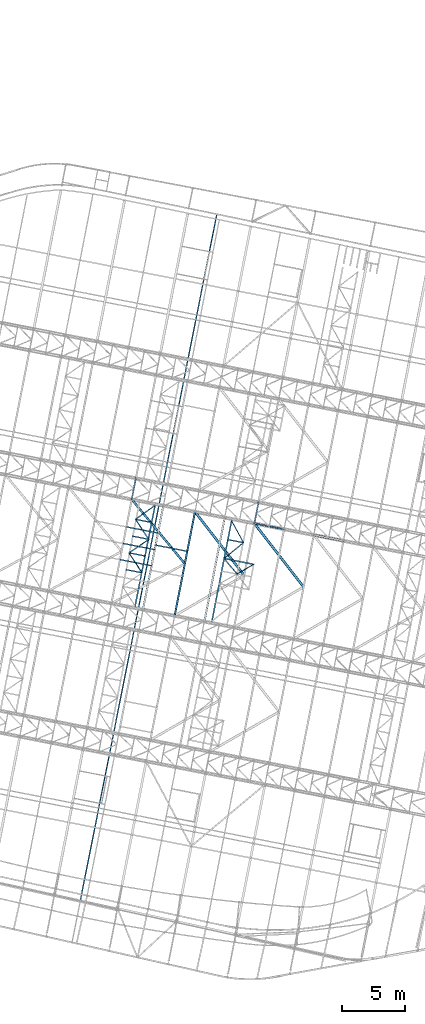
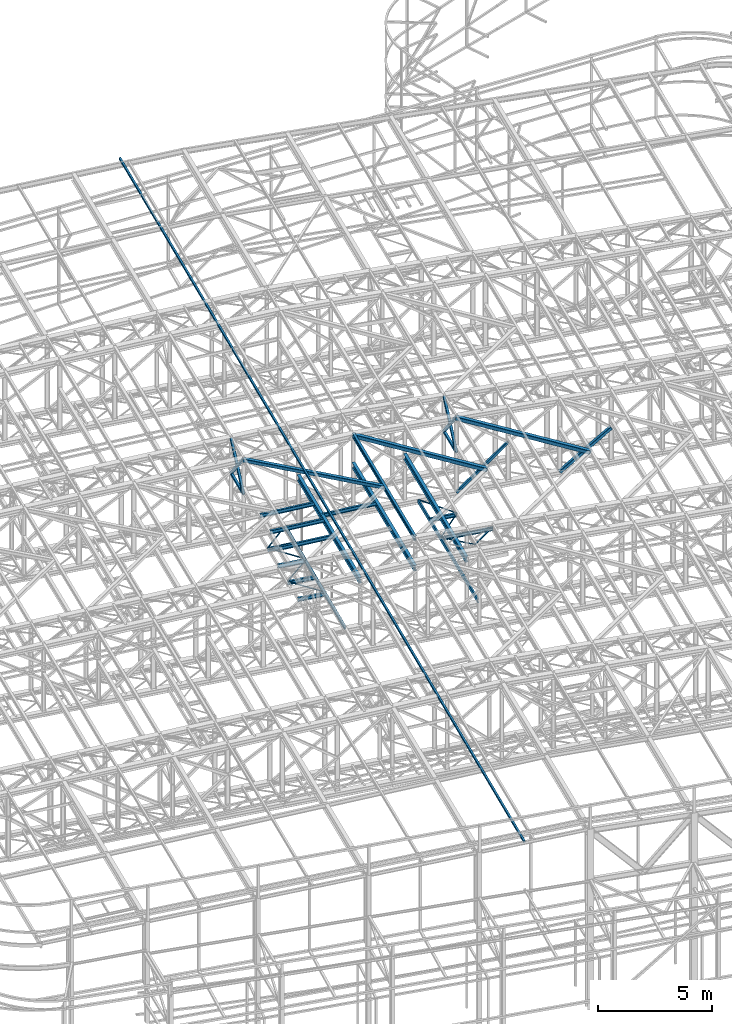
# One storey, part 89 of 215: 30 beams, 6 members, 36 elements without a shape of their own.
"""IFC2X3 building model written with IfcOpenShell, lengths in millimetres."""

from ifc_helpers import new_model, si_unit, frame, origin_with_axes, origin_2d_with_axis, place, context, subcontext, project, spatial, hollow_rectangle, i_section, u_section, extrude, material, type_object, element, aggregate, save


model = new_model("IFC2X3")

# Units and contexts
model_context = context("Model", 3, precision=1e-05, world=origin_with_axes())
body_context = subcontext(model_context, "Body", "Model", "MODEL_VIEW")
ifc_project = project(units=[si_unit("LENGTHUNIT", "METRE", prefix="MILLI"), si_unit("AREAUNIT", "SQUARE_METRE"), si_unit("VOLUMEUNIT", "CUBIC_METRE"), si_unit("MASSUNIT", "GRAM", prefix="KILO"), si_unit("TIMEUNIT", "SECOND"), si_unit("PLANEANGLEUNIT", "RADIAN"), si_unit("SOLIDANGLEUNIT", "STERADIAN"), si_unit("THERMODYNAMICTEMPERATUREUNIT", "DEGREE_CELSIUS"), si_unit("LUMINOUSINTENSITYUNIT", "LUMEN")], contexts=[model_context])

# Site, building, storey
site_placement = place(None, origin_with_axes())
site = spatial("IfcSite", under=ifc_project, at=site_placement, CompositionType="ELEMENT")
building_placement = place(site_placement, origin_with_axes())
building = spatial("IfcBuilding", under=site, at=building_placement, Name="Undefined", CompositionType="ELEMENT")
storey_placement = place(building_placement, origin_with_axes())
storey = spatial("IfcBuildingStorey", under=building, at=storey_placement, Name="Undefined", CompositionType="ELEMENT", Elevation=0.0)

# Assembly, beam
assembly_1_placement = place(storey_placement, origin_with_axes())
assembly_1 = element("IfcElementAssembly", 1, at=assembly_1_placement, inside=storey, Name="Steel Assembly", AssemblyPlace="NOTDEFINED", PredefinedType="RIGID_FRAME")
ifc_material = material(Name="STEEL/S275JR")
beam_type_1 = type_object("IfcBeamType", Name="IPE240", PredefinedType="NOTDEFINED")
beam_1_placement = place(assembly_1_placement, frame((69441.6199476137, 28917.9851493895, 12797.7153095004), z_axis=(0.0, 0.0, 1.0), x_axis=(0.191859470081235, 0.981422408415534, 0.0)))
beam_1 = element("IfcBeam", 2, at=beam_1_placement, type_object=beam_type_1, material=ifc_material, ObjectType="IPE240", context=body_context, shape_type="SweptSolid", body=[
    extrude(i_section(OverallWidth=120.0, OverallDepth=240.0, WebThickness=6.199999809, FlangeThickness=9.800000191, FilletRadius=15.0, at=origin_2d_with_axis()), frame((8361.40106173832, 0.0, -1.81898940354586e-12), z_axis=(-1.0, 0.0, 0.0), x_axis=(-6.93889390390723e-18, -1.0, -3.46944695195361e-18)), (0.0, 0.0, 1.0), 8361.4),
])
aggregate(assembly_1, [beam_1])

assembly_2_placement = place(storey_placement, origin_with_axes())
assembly_2 = element("IfcElementAssembly", 3, at=assembly_2_placement, inside=storey, Name="Steel Assembly", AssemblyPlace="NOTDEFINED", PredefinedType="RIGID_FRAME")
beam_type_2 = type_object("IfcBeamType", PredefinedType="NOTDEFINED")
beam_2_placement = place(assembly_2_placement, frame((66053.3817885931, 38100.0320826268, 10796.0000009293), z_axis=(0.981422364268518, -0.191859461052493, -0.000300197000082615), x_axis=(0.191859470081235, 0.981422408415534, 0.0)))
beam_2 = element("IfcBeam", 4, at=beam_2_placement, type_object=beam_type_2, material=ifc_material, context=body_context, shape_type="SweptSolid", body=[
    extrude(hollow_rectangle(XDim=120.0, YDim=120.0, WallThickness=5.0, InnerFilletRadius=5.0, OuterFilletRadius=10.0, at=origin_2d_with_axis()), frame((1699.99999941724, 1.81898940354586e-12, 0.0), z_axis=(-1.0, 0.0, 0.0), x_axis=(-6.93889390390723e-18, -1.0, -3.46944695195361e-18)), (0.0, 0.0, 1.0), 1700.0),
])
aggregate(assembly_2, [beam_2])

assembly_3_placement = place(storey_placement, origin_with_axes())
assembly_3 = element("IfcElementAssembly", 5, at=assembly_3_placement, inside=storey, Name="Steel Assembly", AssemblyPlace="NOTDEFINED", PredefinedType="RIGID_FRAME")
beam_3_placement = place(assembly_3_placement, frame((75733.9263345548, 36207.5706002678, 10796.0000008389), z_axis=(0.981422364268518, -0.191859461052493, -0.000300197000082615), x_axis=(0.191859470081235, 0.981422408415534, 0.0)))
beam_3 = element("IfcBeam", 6, at=beam_3_placement, type_object=beam_type_2, material=ifc_material, context=body_context, shape_type="SweptSolid", body=[
    extrude(hollow_rectangle(XDim=120.0, YDim=120.0, WallThickness=5.0, InnerFilletRadius=5.0, OuterFilletRadius=10.0, at=origin_2d_with_axis()), frame((1699.99999941724, 1.81898940354586e-12, 0.0), z_axis=(-1.0, 0.0, 0.0), x_axis=(-6.93889390390723e-18, -1.0, -3.46944695195361e-18)), (0.0, 0.0, 1.0), 1700.0),
])
aggregate(assembly_3, [beam_3])

assembly_4_placement = place(storey_placement, origin_with_axes())
assembly_4 = element("IfcElementAssembly", 7, at=assembly_4_placement, inside=storey, Name="Steel Assembly", AssemblyPlace="NOTDEFINED", PredefinedType="RIGID_FRAME")
beam_type_3 = type_object("IfcBeamType", PredefinedType="NOTDEFINED")
beam_4_placement = place(assembly_4_placement, frame((72760.2637128442, 60568.6619986284, 12780.1499996606), z_axis=(0.0, 0.0, -1.0), x_axis=(-0.195014663939707, -0.980800326696766, 0.0)))
beam_4 = element("IfcBeam", 8, at=beam_4_placement, type_object=beam_type_3, material=ifc_material, context=body_context, shape_type="SweptSolid", body=[
    extrude(hollow_rectangle(XDim=100.0, YDim=100.0, WallThickness=5.0, InnerFilletRadius=5.0, OuterFilletRadius=10.0, at=origin_2d_with_axis()), frame((55160.4970435817, 0.0, 0.0), z_axis=(-1.0, 0.0, 0.0), x_axis=(-6.93889390390723e-18, -1.0, -3.46944695195361e-18)), (0.0, 0.0, 1.0), 55160.5),
])
aggregate(assembly_4, [beam_4])

assembly_5_placement = place(storey_placement, origin_with_axes())
assembly_5 = element("IfcElementAssembly", 9, at=assembly_5_placement, inside=storey, Name="Steel Assembly", AssemblyPlace="NOTDEFINED", PredefinedType="RIGID_FRAME")
beam_type_4 = type_object("IfcBeamType", PredefinedType="NOTDEFINED")
beam_5_placement = place(assembly_5_placement, frame((74359.2220523263, 32211.0411013348, 8745.0), z_axis=(0.0, 0.0, -1.0), x_axis=(0.865085284171223, 0.501624811099286, 0.0)))
beam_5 = element("IfcBeam", 10, at=beam_5_placement, type_object=beam_type_4, material=ifc_material, context=body_context, shape_type="SweptSolid", body=[
    extrude(hollow_rectangle(XDim=50.0, YDim=50.0, WallThickness=3.0, InnerFilletRadius=3.0, OuterFilletRadius=6.0, at=origin_2d_with_axis()), frame((1527.85111039409, 0.0, 0.0), z_axis=(-1.0, 0.0, 0.0), x_axis=(-6.93889390390723e-18, -1.0, -3.46944695195361e-18)), (0.0, 0.0, 1.0), 1527.9),
])
aggregate(assembly_5, [beam_5])

assembly_6_placement = place(storey_placement, origin_with_axes())
assembly_6 = element("IfcElementAssembly", 11, at=assembly_6_placement, inside=storey, Name="Steel Assembly", AssemblyPlace="NOTDEFINED", PredefinedType="RIGID_FRAME")
beam_6_placement = place(assembly_6_placement, frame((65844.2206789095, 33881.0831228523, 8745.0), z_axis=(0.0, 0.0, -1.0), x_axis=(0.548855965911927, -0.835916938865869, 0.0)))
beam_6 = element("IfcBeam", 12, at=beam_6_placement, type_object=beam_type_4, material=ifc_material, context=body_context, shape_type="SweptSolid", body=[
    extrude(hollow_rectangle(XDim=50.0, YDim=50.0, WallThickness=3.0, InnerFilletRadius=3.0, OuterFilletRadius=6.0, at=origin_2d_with_axis()), frame((1883.66878465616, -1.04564622774648e-13, 0.0), z_axis=(-1.0, 0.0, 0.0), x_axis=(-6.93889390390723e-18, -1.0, -3.46944695195361e-18)), (0.0, 0.0, 1.0), 1883.7),
])
aggregate(assembly_6, [beam_6])

assembly_7_placement = place(storey_placement, origin_with_axes())
assembly_7 = element("IfcElementAssembly", 13, at=assembly_7_placement, inside=storey, Name="Steel Assembly", AssemblyPlace="NOTDEFINED", PredefinedType="RIGID_FRAME")
beam_7_placement = place(assembly_7_placement, frame((67403.2593053006, 34948.6186588455, 8745.0), z_axis=(0.0, 0.0, -1.0), x_axis=(-0.825103750861284, -0.564981238905011, 0.0)))
beam_7 = element("IfcBeam", 14, at=beam_7_placement, type_object=beam_type_4, material=ifc_material, context=body_context, shape_type="SweptSolid", body=[
    extrude(hollow_rectangle(XDim=50.0, YDim=50.0, WallThickness=3.0, InnerFilletRadius=3.0, OuterFilletRadius=6.0, at=origin_2d_with_axis()), frame((1889.50616827616, 0.0, 0.0), z_axis=(-1.0, 0.0, 0.0), x_axis=(-6.93889390390723e-18, -1.0, -3.46944695195361e-18)), (0.0, 0.0, 1.0), 1889.5),
])
aggregate(assembly_7, [beam_7])

assembly_8_placement = place(storey_placement, origin_with_axes())
assembly_8 = element("IfcElementAssembly", 15, at=assembly_8_placement, inside=storey, Name="Steel Assembly", AssemblyPlace="NOTDEFINED", PredefinedType="RIGID_FRAME")
beam_8_placement = place(assembly_8_placement, frame((66361.7599235187, 36524.7007254203, 8745.0), z_axis=(0.0, 0.0, -1.0), x_axis=(0.551316018014601, -0.834296499022095, 0.0)))
beam_8 = element("IfcBeam", 16, at=beam_8_placement, type_object=beam_type_4, material=ifc_material, context=body_context, shape_type="SweptSolid", body=[
    extrude(hollow_rectangle(XDim=50.0, YDim=50.0, WallThickness=3.0, InnerFilletRadius=3.0, OuterFilletRadius=6.0, at=origin_2d_with_axis()), frame((1889.11504236004, 1.04866950809692e-13, 0.0), z_axis=(-1.0, 0.0, 0.0), x_axis=(-6.93889390390723e-18, -1.0, -3.46944695195361e-18)), (0.0, 0.0, 1.0), 1889.1),
])
aggregate(assembly_8, [beam_8])

assembly_9_placement = place(storey_placement, origin_with_axes())
assembly_9 = element("IfcElementAssembly", 17, at=assembly_9_placement, inside=storey, Name="Steel Assembly", AssemblyPlace="NOTDEFINED", PredefinedType="RIGID_FRAME")
beam_9_placement = place(assembly_9_placement, frame((67851.6645901151, 37597.2244133105, 8745.0), z_axis=(0.0, 0.0, -1.0), x_axis=(-0.811587979018068, -0.584230222013008, 0.0)))
beam_9 = element("IfcBeam", 18, at=beam_9_placement, type_object=beam_type_4, material=ifc_material, context=body_context, shape_type="SweptSolid", body=[
    extrude(hollow_rectangle(XDim=50.0, YDim=50.0, WallThickness=3.0, InnerFilletRadius=3.0, OuterFilletRadius=6.0, at=origin_2d_with_axis()), frame((1835.78946943033, 0.0, 0.0), z_axis=(-1.0, 0.0, 0.0), x_axis=(-6.93889390390723e-18, -1.0, -3.46944695195361e-18)), (0.0, 0.0, 1.0), 1835.8),
])
aggregate(assembly_9, [beam_9])

assembly_10_placement = place(storey_placement, origin_with_axes())
assembly_10 = element("IfcElementAssembly", 19, at=assembly_10_placement, inside=storey, Name="Steel Assembly", AssemblyPlace="NOTDEFINED", PredefinedType="RIGID_FRAME")
beam_10_placement = place(assembly_10_placement, frame((73349.8715093895, 33433.7505785208, 8745.0), z_axis=(0.0, 0.0, -1.0), x_axis=(0.636615101097475, -0.771181699118082, 0.0)))
beam_10 = element("IfcBeam", 20, at=beam_10_placement, type_object=beam_type_4, material=ifc_material, context=body_context, shape_type="SweptSolid", body=[
    extrude(hollow_rectangle(XDim=50.0, YDim=50.0, WallThickness=3.0, InnerFilletRadius=3.0, OuterFilletRadius=6.0, at=origin_2d_with_axis()), frame((1585.49676732963, -5.45696821063757e-12, -1.81898940354586e-12), z_axis=(-1.0, 0.0, 0.0), x_axis=(-6.93889390390723e-18, -1.0, -3.46944695195361e-18)), (0.0, 0.0, 1.0), 1585.5),
])
aggregate(assembly_10, [beam_10])

assembly_11_placement = place(storey_placement, origin_with_axes())
assembly_11 = element("IfcElementAssembly", 21, at=assembly_11_placement, inside=storey, Name="Steel Assembly", AssemblyPlace="NOTDEFINED", PredefinedType="RIGID_FRAME")
beam_11_placement = place(assembly_11_placement, frame((74880.7345847299, 34683.1015991232, 8745.0), z_axis=(0.0, 0.0, -1.0), x_axis=(-0.774743780939368, -0.632275314950514, 0.0)))
beam_11 = element("IfcBeam", 22, at=beam_11_placement, type_object=beam_type_4, material=ifc_material, context=body_context, shape_type="SweptSolid", body=[
    extrude(hollow_rectangle(XDim=50.0, YDim=50.0, WallThickness=3.0, InnerFilletRadius=3.0, OuterFilletRadius=6.0, at=origin_2d_with_axis()), frame((1975.96045713985, 0.0, 0.0), z_axis=(-1.0, 0.0, 0.0), x_axis=(-6.93889390390723e-18, -1.0, -3.46944695195361e-18)), (0.0, 0.0, 1.0), 1976.0),
])
aggregate(assembly_11, [beam_11])

assembly_12_placement = place(storey_placement, origin_with_axes())
assembly_12 = element("IfcElementAssembly", 23, at=assembly_12_placement, inside=storey, Name="Steel Assembly", AssemblyPlace="NOTDEFINED", PredefinedType="RIGID_FRAME")
beam_12_placement = place(assembly_12_placement, frame((73933.5312791089, 36416.8755526953, 8745.0), z_axis=(0.0, 0.0, -1.0), x_axis=(0.479440460054689, -0.877574410100106, 0.0)))
beam_12 = element("IfcBeam", 24, at=beam_12_placement, type_object=beam_type_4, material=ifc_material, context=body_context, shape_type="SweptSolid", body=[
    extrude(hollow_rectangle(XDim=50.0, YDim=50.0, WallThickness=3.0, InnerFilletRadius=3.0, OuterFilletRadius=6.0, at=origin_2d_with_axis()), frame((1975.64324325038, 0.0, 1.81898940354586e-12), z_axis=(-1.0, 0.0, 0.0), x_axis=(-6.93889390390723e-18, -1.0, -3.46944695195361e-18)), (0.0, 0.0, 1.0), 1975.6),
])
aggregate(assembly_12, [beam_12])

assembly_13_placement = place(storey_placement, origin_with_axes())
assembly_13 = element("IfcElementAssembly", 25, at=assembly_13_placement, inside=storey, Name="Steel Assembly", AssemblyPlace="NOTDEFINED", PredefinedType="RIGID_FRAME")
beam_type_5 = type_object("IfcBeamType", Name="UPN200", PredefinedType="NOTDEFINED")
beam_13_placement = place(assembly_13_placement, frame((75717.7385794885, 32970.2465947145, 8670.00000000005), z_axis=(0.0, 0.0, -1.0), x_axis=(-0.981375028054853, 0.192101677010737, 0.0)))
beam_13 = element("IfcBeam", 26, at=beam_13_placement, type_object=beam_type_5, material=ifc_material, ObjectType="UPN200", context=body_context, shape_type="SweptSolid", body=[
    extrude(u_section(Depth=200.0, FlangeWidth=75.0, WebThickness=8.5, FlangeThickness=11.5, FilletRadius=11.5, EdgeRadius=6.0, FlangeSlope=0.0798299857122373, at=origin_2d_with_axis()), frame((2450.34508988503, -7.27595761418343e-12, -1.81898940354586e-12), z_axis=(-1.0, 0.0, 0.0), x_axis=(-6.93889390390723e-18, -1.0, -3.46944695195361e-18)), (0.0, 0.0, 1.0), 2450.3),
])
aggregate(assembly_13, [beam_13])

assembly_14_placement = place(storey_placement, origin_with_axes())
assembly_14 = element("IfcElementAssembly", 27, at=assembly_14_placement, inside=storey, Name="Steel Assembly", AssemblyPlace="NOTDEFINED", PredefinedType="RIGID_FRAME")
beam_14_placement = place(assembly_14_placement, frame((66315.9862229072, 29671.7920280881, 8670.00000000005), z_axis=(0.0, 0.0, -1.0), x_axis=(0.195014663939708, 0.980800326696766, 0.0)))
beam_14 = element("IfcBeam", 28, at=beam_14_placement, type_object=beam_type_5, material=ifc_material, ObjectType="UPN200", context=body_context, shape_type="SweptSolid", body=[
    extrude(u_section(Depth=200.0, FlangeWidth=75.0, WebThickness=8.5, FlangeThickness=11.5, FilletRadius=11.5, EdgeRadius=6.0, FlangeSlope=0.0798299857122373, at=origin_2d_with_axis()), frame((8072.90847915131, -2.24068221731136e-13, -1.81898940354586e-12), z_axis=(-1.0, 0.0, 0.0), x_axis=(-6.93889390390723e-18, -1.0, -3.46944695195361e-18)), (0.0, 0.0, 1.0), 8072.9),
])
aggregate(assembly_14, [beam_14])

assembly_15_placement = place(storey_placement, origin_with_axes())
assembly_15 = element("IfcElementAssembly", 29, at=assembly_15_placement, inside=storey, Name="Steel Assembly", AssemblyPlace="NOTDEFINED", PredefinedType="RIGID_FRAME")
beam_15_placement = place(assembly_15_placement, frame((73933.5312791089, 36416.8755526953, 8670.00000003361), z_axis=(0.0, 0.0, -1.0), x_axis=(-0.192024987929021, -0.981390036637248, 0.0)))
beam_15 = element("IfcBeam", 30, at=beam_15_placement, type_object=beam_type_5, material=ifc_material, ObjectType="UPN200", context=body_context, shape_type="SweptSolid", body=[
    extrude(u_section(Depth=200.0, FlangeWidth=75.0, WebThickness=8.5, FlangeThickness=11.5, FilletRadius=11.5, EdgeRadius=6.0, FlangeSlope=0.0798299857122373, at=origin_2d_with_axis()), frame((8081.40119386646, 2.24303941916594e-13, 0.0), z_axis=(-1.0, 0.0, 0.0), x_axis=(-6.93889390390723e-18, -1.0, -3.46944695195361e-18)), (0.0, 0.0, 1.0), 8081.4),
])
aggregate(assembly_15, [beam_15])

# Assembly, member
assembly_16_placement = place(storey_placement, origin_with_axes())
assembly_16 = element("IfcElementAssembly", 31, at=assembly_16_placement, inside=storey, Name="Steel Assembly", AssemblyPlace="NOTDEFINED", PredefinedType="RIGID_FRAME")
member_type_1 = type_object("IfcMemberType", PredefinedType="NOTDEFINED")
member_1_placement = place(assembly_16_placement, frame((66379.5428872718, 39768.4501764451, 10796.0000009276), z_axis=(0.981465045882622, -0.191641130977078, 0.000201564999975286), x_axis=(-0.128822807021333, -0.658969764109112, 0.741055689122704)))
member_1 = element("IfcMember", 32, at=member_1_placement, type_object=member_type_1, material=ifc_material, context=body_context, shape_type="SweptSolid", body=[
    extrude(hollow_rectangle(XDim=120.0, YDim=120.0, WallThickness=5.0, InnerFilletRadius=5.0, OuterFilletRadius=10.0, at=origin_2d_with_axis()), frame((2531.85832868423, -6.99486487302401e-12, 7.33099579250614e-12), z_axis=(-1.0, 0.0, 0.0), x_axis=(-6.93889390390723e-18, -1.0, -3.46944695195361e-18)), (0.0, 0.0, 1.0), 2531.9),
])
aggregate(assembly_16, [member_1])

assembly_17_placement = place(storey_placement, origin_with_axes())
assembly_17 = element("IfcElementAssembly", 33, at=assembly_17_placement, inside=storey, Name="Steel Assembly", AssemblyPlace="NOTDEFINED", PredefinedType="RIGID_FRAME")
member_2_placement = place(assembly_17_placement, frame((66053.3817885931, 38100.0320826268, 10796.0000009293), z_axis=(0.981465045882622, -0.191641130977078, -0.000201564999975286), x_axis=(0.128822807951567, 0.658969767752257, 0.741055685721397)))
member_2 = element("IfcMember", 34, at=member_2_placement, type_object=member_type_1, material=ifc_material, context=body_context, shape_type="SweptSolid", body=[
    extrude(hollow_rectangle(XDim=120.0, YDim=120.0, WallThickness=5.0, InnerFilletRadius=5.0, OuterFilletRadius=10.0, at=origin_2d_with_axis()), frame((2531.85832868423, -6.99486487302401e-12, 7.33099579250614e-12), z_axis=(-1.0, 0.0, 0.0), x_axis=(-6.93889390390723e-18, -1.0, -3.46944695195361e-18)), (0.0, 0.0, 1.0), 2531.9),
])
aggregate(assembly_17, [member_2])

assembly_18_placement = place(storey_placement, origin_with_axes())
assembly_18 = element("IfcElementAssembly", 35, at=assembly_18_placement, inside=storey, Name="Steel Assembly", AssemblyPlace="NOTDEFINED", PredefinedType="RIGID_FRAME")
member_3_placement = place(assembly_18_placement, frame((76060.0874332191, 37875.9886940822, 10796.0000008371), z_axis=(0.981465144014204, -0.191640629002775, 0.000200999000003501), x_axis=(-0.128461058963395, -0.657119307812757, 0.742759699788354)))
member_3 = element("IfcMember", 36, at=member_3_placement, type_object=member_type_1, material=ifc_material, context=body_context, shape_type="SweptSolid", body=[
    extrude(hollow_rectangle(XDim=120.0, YDim=120.0, WallThickness=5.0, InnerFilletRadius=5.0, OuterFilletRadius=10.0, at=origin_2d_with_axis()), frame((2538.98807297308, -7.4168997650766e-12, -1.4616192556948e-11), z_axis=(-1.0, 0.0, 0.0), x_axis=(-6.93889390390723e-18, -1.0, -3.46944695195361e-18)), (0.0, 0.0, 1.0), 2539.0),
])
aggregate(assembly_18, [member_3])

assembly_19_placement = place(storey_placement, origin_with_axes())
assembly_19 = element("IfcElementAssembly", 37, at=assembly_19_placement, inside=storey, Name="Steel Assembly", AssemblyPlace="NOTDEFINED", PredefinedType="RIGID_FRAME")
member_4_placement = place(assembly_19_placement, frame((75733.9263345548, 36207.5706002678, 10796.0000008389), z_axis=(0.981465144014204, -0.191640629002775, -0.000200999000003501), x_axis=(0.128461059990898, 0.657119311953447, 0.742759695947379)))
member_4 = element("IfcMember", 38, at=member_4_placement, type_object=member_type_1, material=ifc_material, context=body_context, shape_type="SweptSolid", body=[
    extrude(hollow_rectangle(XDim=120.0, YDim=120.0, WallThickness=5.0, InnerFilletRadius=5.0, OuterFilletRadius=10.0, at=origin_2d_with_axis()), frame((2538.98807297308, -7.4168997650766e-12, -1.4616192556948e-11), z_axis=(-1.0, 0.0, 0.0), x_axis=(-6.93889390390723e-18, -1.0, -3.46944695195361e-18)), (0.0, 0.0, 1.0), 2539.0),
])
aggregate(assembly_19, [member_4])

assembly_20_placement = place(storey_placement, origin_with_axes())
assembly_20 = element("IfcElementAssembly", 39, at=assembly_20_placement, inside=storey, Name="Steel Assembly", AssemblyPlace="NOTDEFINED", PredefinedType="RIGID_FRAME")
member_5_placement = place(assembly_20_placement, frame((75733.8038261221, 36206.9473002579, 8635.00000002286), z_axis=(0.658795867060445, -0.12879937101182, -0.741214360068014), x_axis=(0.727444441074387, -0.142208697014541, 0.671268405068643)))
member_5 = element("IfcMember", 40, at=member_5_placement, type_object=member_type_1, material=ifc_material, context=body_context, shape_type="SweptSolid", body=[
    extrude(hollow_rectangle(XDim=120.0, YDim=120.0, WallThickness=5.0, InnerFilletRadius=5.0, OuterFilletRadius=10.0, at=origin_2d_with_axis()), frame((3220.54913749736, 7.11337137710058e-12, -7.63351039462205e-12), z_axis=(-1.0, 0.0, 0.0), x_axis=(-6.93889390390723e-18, -1.0, -3.46944695195361e-18)), (0.0, 0.0, 1.0), 3220.5),
])
aggregate(assembly_20, [member_5])

# Assembly, beam
assembly_21_placement = place(storey_placement, origin_with_axes())
assembly_21 = element("IfcElementAssembly", 41, at=assembly_21_placement, inside=storey, Name="Steel Assembly", AssemblyPlace="NOTDEFINED", PredefinedType="RIGID_FRAME")
beam_type_6 = type_object("IfcBeamType", PredefinedType="NOTDEFINED")
beam_16_placement = place(assembly_21_placement, frame((74927.8233424077, 32105.5698567078, 12638.8209968543), z_axis=(0.0303378029878793, -0.00559570999776539, 0.999524039600594), x_axis=(-0.612030851936216, 0.790499299917617, 0.0230020239976028)))
beam_16 = element("IfcBeam", 42, at=beam_16_placement, type_object=beam_type_6, material=ifc_material, context=body_context, shape_type="SweptSolid", body=[
    extrude(hollow_rectangle(XDim=200.0, YDim=200.0, WallThickness=10.0, InnerFilletRadius=15.0, OuterFilletRadius=25.0, at=origin_2d_with_axis()), frame((6349.51246722592, -6.06494074105851e-13, -1.81898940354586e-12), z_axis=(-1.0, 0.0, 0.0), x_axis=(-6.93889390390723e-18, -1.0, -3.46944695195361e-18)), (0.0, 0.0, 1.0), 6349.5),
])
aggregate(assembly_21, [beam_16])

assembly_22_placement = place(storey_placement, origin_with_axes())
assembly_22 = element("IfcElementAssembly", 43, at=assembly_22_placement, inside=storey, Name="Steel Assembly", AssemblyPlace="NOTDEFINED", PredefinedType="RIGID_FRAME")
beam_17_placement = place(assembly_22_placement, frame((79615.9190772174, 31189.0882383297, 12490.7460979052), z_axis=(0.0303378029878793, -0.00559570999776539, 0.999524039600594), x_axis=(-0.612030851936216, 0.790499299917617, 0.0230020239976028)))
beam_17 = element("IfcBeam", 44, at=beam_17_placement, type_object=beam_type_6, material=ifc_material, context=body_context, shape_type="SweptSolid", body=[
    extrude(hollow_rectangle(XDim=200.0, YDim=200.0, WallThickness=10.0, InnerFilletRadius=15.0, OuterFilletRadius=25.0, at=origin_2d_with_axis()), frame((6349.51246722592, -6.06494074105851e-13, -1.81898940354586e-12), z_axis=(-1.0, 0.0, 0.0), x_axis=(-6.93889390390723e-18, -1.0, -3.46944695195361e-18)), (0.0, 0.0, 1.0), 6349.5),
])
aggregate(assembly_22, [beam_17])

assembly_23_placement = place(storey_placement, origin_with_axes())
assembly_23 = element("IfcElementAssembly", 45, at=assembly_23_placement, inside=storey, Name="Steel Assembly", AssemblyPlace="NOTDEFINED", PredefinedType="RIGID_FRAME")
beam_type_7 = type_object("IfcBeamType", PredefinedType="NOTDEFINED")
beam_18_placement = place(assembly_23_placement, frame((70247.7684552626, 33020.2282585387, 12784.8705300003), z_axis=(-0.0304080349967745, 0.00594450299936818, 0.999519891893966), x_axis=(-0.636209844962318, 0.771144499954326, -0.023941456998582)))
beam_18 = element("IfcBeam", 46, at=beam_18_placement, type_object=beam_type_7, material=ifc_material, context=body_context, shape_type="SweptSolid", body=[
    extrude(hollow_rectangle(XDim=180.0, YDim=180.0, WallThickness=8.0, InnerFilletRadius=12.0, OuterFilletRadius=20.0, at=origin_2d_with_axis()), frame((6586.31471164171, 8.67261906526822e-13, 1.84184027304677e-12), z_axis=(-1.0, 0.0, 0.0), x_axis=(-6.93889390390723e-18, -1.0, -3.46944695195361e-18)), (0.0, 0.0, 1.0), 6586.3),
])
aggregate(assembly_23, [beam_18])

assembly_24_placement = place(storey_placement, origin_with_axes())
assembly_24 = element("IfcElementAssembly", 47, at=assembly_24_placement, inside=storey, Name="Steel Assembly", AssemblyPlace="NOTDEFINED", PredefinedType="RIGID_FRAME")
beam_type_8 = type_object("IfcBeamType", Name="IPE300", PredefinedType="NOTDEFINED")
beam_19_placement = place(assembly_24_placement, frame((71785.6690730683, 28459.7441744276, 11123.8100001495), z_axis=(0.0, 0.0, 1.0), x_axis=(0.191859470081235, 0.981422408415534, 0.0)))
beam_19 = element("IfcBeam", 48, at=beam_19_placement, type_object=beam_type_8, material=ifc_material, Name="SUPPORT", ObjectType="IPE300", context=body_context, shape_type="SweptSolid", body=[
    extrude(i_section(OverallWidth=150.0, OverallDepth=300.0, WebThickness=7.099999905, FlangeThickness=10.69999981, FilletRadius=15.0, at=origin_2d_with_axis()), frame((8361.40106173832, 0.0, -1.81898940354586e-12), z_axis=(-1.0, 0.0, 0.0), x_axis=(-6.93889390390723e-18, -1.0, -3.46944695195361e-18)), (0.0, 0.0, 1.0), 8361.4),
])
aggregate(assembly_24, [beam_19])

assembly_25_placement = place(storey_placement, origin_with_axes())
assembly_25 = element("IfcElementAssembly", 49, at=assembly_25_placement, inside=storey, Name="Steel Assembly", AssemblyPlace="NOTDEFINED", PredefinedType="RIGID_FRAME")
beam_20_placement = place(assembly_25_placement, frame((69441.6211921765, 28917.9849215023, 11197.7200001516), z_axis=(0.0, 0.0, 1.0), x_axis=(0.191859470081235, 0.981422408415534, 0.0)))
beam_20 = element("IfcBeam", 50, at=beam_20_placement, type_object=beam_type_8, material=ifc_material, Name="SUPPORT", ObjectType="IPE300", context=body_context, shape_type="SweptSolid", body=[
    extrude(i_section(OverallWidth=150.0, OverallDepth=300.0, WebThickness=7.099999905, FlangeThickness=10.69999981, FilletRadius=15.0, at=origin_2d_with_axis()), frame((8361.40106173832, 0.0, -1.81898940354586e-12), z_axis=(-1.0, 0.0, 0.0), x_axis=(-6.93889390390723e-18, -1.0, -3.46944695195361e-18)), (0.0, 0.0, 1.0), 8361.4),
])
aggregate(assembly_25, [beam_20])

assembly_26_placement = place(storey_placement, origin_with_axes())
assembly_26 = element("IfcElementAssembly", 51, at=assembly_26_placement, inside=storey, Name="Steel Assembly", AssemblyPlace="NOTDEFINED", PredefinedType="RIGID_FRAME")
beam_21_placement = place(assembly_26_placement, frame((66945.3970877397, 29405.9747819319, 11119.0000001701), z_axis=(0.0, 0.0, 1.0), x_axis=(0.191859470081235, 0.981422408415534, 0.0)))
beam_21 = element("IfcBeam", 52, at=beam_21_placement, type_object=beam_type_8, material=ifc_material, Name="SUPPORT", ObjectType="IPE300", context=body_context, shape_type="SweptSolid", body=[
    extrude(i_section(OverallWidth=150.0, OverallDepth=300.0, WebThickness=7.099999905, FlangeThickness=10.69999981, FilletRadius=15.0, at=origin_2d_with_axis()), frame((8361.40106173832, 0.0, -1.81898940354586e-12), z_axis=(-1.0, 0.0, 0.0), x_axis=(-6.93889390390723e-18, -1.0, -3.46944695195361e-18)), (0.0, 0.0, 1.0), 8361.4),
])
aggregate(assembly_26, [beam_21])

assembly_27_placement = place(storey_placement, origin_with_axes())
assembly_27 = element("IfcElementAssembly", 53, at=assembly_27_placement, inside=storey, Name="Steel Assembly", AssemblyPlace="NOTDEFINED", PredefinedType="RIGID_FRAME")
beam_type_9 = type_object("IfcBeamType", Name="IPE200", PredefinedType="NOTDEFINED")
beam_22_placement = place(assembly_27_placement, frame((66877.9257268223, 32306.5233391649, 8670.00000000005), z_axis=(0.0, 0.0, -1.0), x_axis=(-0.981410464467207, 0.191920557091367, 0.0)))
beam_22 = element("IfcBeam", 54, at=beam_22_placement, type_object=beam_type_9, material=ifc_material, ObjectType="IPE200", context=body_context, shape_type="SweptSolid", body=[
    extrude(i_section(OverallWidth=100.0, OverallDepth=200.0, WebThickness=5.599999905, FlangeThickness=8.5, FilletRadius=12.0, at=origin_2d_with_axis()), frame((1316.95627574167, 0.0, 0.0), z_axis=(-1.0, 0.0, 0.0), x_axis=(-6.93889390390723e-18, -1.0, -3.46944695195361e-18)), (0.0, 0.0, 1.0), 1317.0),
])
aggregate(assembly_27, [beam_22])

assembly_28_placement = place(storey_placement, origin_with_axes())
assembly_28 = element("IfcElementAssembly", 55, at=assembly_28_placement, inside=storey, Name="Steel Assembly", AssemblyPlace="NOTDEFINED", PredefinedType="RIGID_FRAME")
beam_23_placement = place(assembly_28_placement, frame((67403.2593053006, 34948.6186588455, 8670.00000000005), z_axis=(0.0, 0.0, -1.0), x_axis=(-0.981410740999988, 0.191919142999998, 0.0)))
beam_23 = element("IfcBeam", 56, at=beam_23_placement, type_object=beam_type_9, material=ifc_material, ObjectType="IPE200", context=body_context, shape_type="SweptSolid", body=[
    extrude(i_section(OverallWidth=100.0, OverallDepth=200.0, WebThickness=5.599999905, FlangeThickness=8.5, FilletRadius=12.0, at=origin_2d_with_axis()), frame((1324.89787396076, -7.27595761418343e-12, 0.0), z_axis=(-1.0, 0.0, 0.0), x_axis=(-6.93889390390723e-18, -1.0, -3.46944695195361e-18)), (0.0, 0.0, 1.0), 1324.9),
])
aggregate(assembly_28, [beam_23])

assembly_29_placement = place(storey_placement, origin_with_axes())
assembly_29 = element("IfcElementAssembly", 57, at=assembly_29_placement, inside=storey, Name="Steel Assembly", AssemblyPlace="NOTDEFINED", PredefinedType="RIGID_FRAME")
beam_24_placement = place(assembly_29_placement, frame((65632.9171736863, 35932.9402682693, 11090.3279375594), z_axis=(0.0303605499861654, -0.00593522099729565, -0.99952139054462), x_axis=(0.980952689077156, -0.191767651015084, 0.030935252002433)))
beam_24 = element("IfcBeam", 58, at=beam_24_placement, type_object=beam_type_9, material=ifc_material, ObjectType="IPE200", context=body_context, shape_type="SweptSolid", body=[
    extrude(i_section(OverallWidth=100.0, OverallDepth=200.0, WebThickness=5.599999905, FlangeThickness=8.5, FilletRadius=12.0, at=origin_2d_with_axis()), frame((2544.66727454958, 2.95700928513306e-14, 1.81016081542643e-12), z_axis=(-1.0, 0.0, 0.0), x_axis=(-6.93889390390723e-18, -1.0, -3.46944695195361e-18)), (0.0, 0.0, 1.0), 2544.7),
])
aggregate(assembly_29, [beam_24])

assembly_30_placement = place(storey_placement, origin_with_axes())
assembly_30 = element("IfcElementAssembly", 59, at=assembly_30_placement, inside=storey, Name="Steel Assembly", AssemblyPlace="NOTDEFINED", PredefinedType="RIGID_FRAME")
beam_25_placement = place(assembly_30_placement, frame((65376.9460863392, 34623.5647857369, 11090.3279375709), z_axis=(0.0303605499861654, -0.00593522099729565, -0.99952139054462), x_axis=(0.980952689077156, -0.191767651015084, 0.030935252002433)))
beam_25 = element("IfcBeam", 60, at=beam_25_placement, type_object=beam_type_9, material=ifc_material, ObjectType="IPE200", context=body_context, shape_type="SweptSolid", body=[
    extrude(i_section(OverallWidth=100.0, OverallDepth=200.0, WebThickness=5.599999905, FlangeThickness=8.5, FilletRadius=12.0, at=origin_2d_with_axis()), frame((2544.66727454958, 2.95700928513306e-14, 1.81016081542643e-12), z_axis=(-1.0, 0.0, 0.0), x_axis=(-6.93889390390723e-18, -1.0, -3.46944695195361e-18)), (0.0, 0.0, 1.0), 2544.7),
])
aggregate(assembly_30, [beam_25])

assembly_31_placement = place(storey_placement, origin_with_axes())
assembly_31 = element("IfcElementAssembly", 61, at=assembly_31_placement, inside=storey, Name="Steel Assembly", AssemblyPlace="NOTDEFINED", PredefinedType="RIGID_FRAME")
beam_26_placement = place(assembly_31_placement, frame((65128.1693099369, 33350.9905593723, 11090.3279375719), z_axis=(0.0303605499861654, -0.00593522099729565, -0.99952139054462), x_axis=(0.980952689077156, -0.191767651015084, 0.030935252002433)))
beam_26 = element("IfcBeam", 62, at=beam_26_placement, type_object=beam_type_9, material=ifc_material, ObjectType="IPE200", context=body_context, shape_type="SweptSolid", body=[
    extrude(i_section(OverallWidth=100.0, OverallDepth=200.0, WebThickness=5.599999905, FlangeThickness=8.5, FilletRadius=12.0, at=origin_2d_with_axis()), frame((2544.66727454958, 2.95700928513306e-14, 1.81016081542643e-12), z_axis=(-1.0, 0.0, 0.0), x_axis=(-6.93889390390723e-18, -1.0, -3.46944695195361e-18)), (0.0, 0.0, 1.0), 2544.7),
])
aggregate(assembly_31, [beam_26])

assembly_32_placement = place(storey_placement, origin_with_axes())
assembly_32 = element("IfcElementAssembly", 63, at=assembly_32_placement, inside=storey, Name="Steel Assembly", AssemblyPlace="NOTDEFINED", PredefinedType="RIGID_FRAME")
beam_27_placement = place(assembly_32_placement, frame((67943.0376463623, 34492.9697180528, 11169.0478651108), z_axis=(0.0303605499861654, -0.00593522099729565, -0.99952139054462), x_axis=(0.980952689077156, -0.191767651015084, 0.030935252002433)))
beam_27 = element("IfcBeam", 64, at=beam_27_placement, type_object=beam_type_9, material=ifc_material, ObjectType="IPE200", context=body_context, shape_type="SweptSolid", body=[
    extrude(i_section(OverallWidth=100.0, OverallDepth=200.0, WebThickness=5.599999905, FlangeThickness=8.5, FilletRadius=12.0, at=origin_2d_with_axis()), frame((2544.66727454958, 2.95700928513306e-14, 1.81016081542643e-12), z_axis=(-1.0, 0.0, 0.0), x_axis=(-6.93889390390723e-18, -1.0, -3.46944695195361e-18)), (0.0, 0.0, 1.0), 2544.7),
])
aggregate(assembly_32, [beam_27])

assembly_33_placement = place(storey_placement, origin_with_axes())
assembly_33 = element("IfcElementAssembly", 65, at=assembly_33_placement, inside=storey, Name="Steel Assembly", AssemblyPlace="NOTDEFINED", PredefinedType="RIGID_FRAME")
beam_28_placement = place(assembly_33_placement, frame((67140.5898807419, 33627.5577822503, 8670.00000000005), z_axis=(0.0, 0.0, -1.0), x_axis=(-0.981408644988118, 0.191929860997675, 0.0)))
beam_28 = element("IfcBeam", 66, at=beam_28_placement, type_object=beam_type_9, material=ifc_material, ObjectType="IPE200", context=body_context, shape_type="SweptSolid", body=[
    extrude(i_section(OverallWidth=100.0, OverallDepth=200.0, WebThickness=5.599999905, FlangeThickness=8.5, FilletRadius=12.0, at=origin_2d_with_axis()), frame((1320.9270251649, -7.20263143432404e-12, 0.0), z_axis=(-1.0, 0.0, 0.0), x_axis=(-6.93889390390723e-18, -1.0, -3.46944695195361e-18)), (0.0, 0.0, 1.0), 1320.9),
])
aggregate(assembly_33, [beam_28])

assembly_34_placement = place(storey_placement, origin_with_axes())
assembly_34 = element("IfcElementAssembly", 67, at=assembly_34_placement, inside=storey, Name="Steel Assembly", AssemblyPlace="NOTDEFINED", PredefinedType="RIGID_FRAME")
beam_29_placement = place(assembly_34_placement, frame((67665.9234592202, 36269.653101931, 8670.00000000005), z_axis=(0.0, 0.0, -1.0), x_axis=(-0.981408931509044, 0.191928395903984, 0.0)))
beam_29 = element("IfcBeam", 68, at=beam_29_placement, type_object=beam_type_9, material=ifc_material, ObjectType="IPE200", context=body_context, shape_type="SweptSolid", body=[
    extrude(i_section(OverallWidth=100.0, OverallDepth=200.0, WebThickness=5.599999905, FlangeThickness=8.5, FilletRadius=12.0, at=origin_2d_with_axis()), frame((1328.86862331426, 0.0, 1.81898940354586e-12), z_axis=(-1.0, 0.0, 0.0), x_axis=(-6.93889390390723e-18, -1.0, -3.46944695195361e-18)), (0.0, 0.0, 1.0), 1328.9),
])
aggregate(assembly_34, [beam_29])

assembly_35_placement = place(storey_placement, origin_with_axes())
assembly_35 = element("IfcElementAssembly", 69, at=assembly_35_placement, inside=storey, Name="Steel Assembly", AssemblyPlace="NOTDEFINED", PredefinedType="RIGID_FRAME")
beam_30_placement = place(assembly_35_placement, frame((74880.7299765797, 34683.1025156256, 8670.00000000005), z_axis=(0.0, 0.0, -1.0), x_axis=(-0.981422412140383, 0.191859451027444, 0.0)))
beam_30 = element("IfcBeam", 70, at=beam_30_placement, type_object=beam_type_9, material=ifc_material, ObjectType="IPE200", context=body_context, shape_type="SweptSolid", body=[
    extrude(i_section(OverallWidth=100.0, OverallDepth=200.0, WebThickness=5.599999905, FlangeThickness=8.5, FilletRadius=12.0, at=origin_2d_with_axis()), frame((1300.00059478047, 0.0, -1.81898940354586e-12), z_axis=(-1.0, 0.0, 0.0), x_axis=(-6.93889390390723e-18, -1.0, -3.46944695195361e-18)), (0.0, 0.0, 1.0), 1300.0),
])
aggregate(assembly_35, [beam_30])

# Assembly, member
assembly_36_placement = place(storey_placement, origin_with_axes())
assembly_36 = element("IfcElementAssembly", 71, at=assembly_36_placement, inside=storey, Name="Steel Assembly", AssemblyPlace="NOTDEFINED", PredefinedType="RIGID_FRAME")
member_type_2 = type_object("IfcMemberType", PredefinedType="NOTDEFINED")
member_6_placement = place(assembly_36_placement, frame((80422.0240430873, 35291.0888163782, 8655.00000001143), z_axis=(0.597857237183729, -0.116875832035918, -0.793036420243705), x_axis=(0.778303714010845, -0.15215154400212, 0.609174225008491)))
member_6 = element("IfcMember", 72, at=member_6_placement, type_object=member_type_2, material=ifc_material, context=body_context, shape_type="SweptSolid", body=[
    extrude(hollow_rectangle(XDim=160.0, YDim=160.0, WallThickness=8.0, InnerFilletRadius=12.0, OuterFilletRadius=20.0, at=origin_2d_with_axis()), frame((3008.52889026435, 7.2846441447338e-12, -5.0102070663322e-13), z_axis=(-1.0, 0.0, 0.0), x_axis=(-6.93889390390723e-18, -1.0, -3.46944695195361e-18)), (0.0, 0.0, 1.0), 3008.5),
])
aggregate(assembly_36, [member_6])

save(model, "model.ifc")
